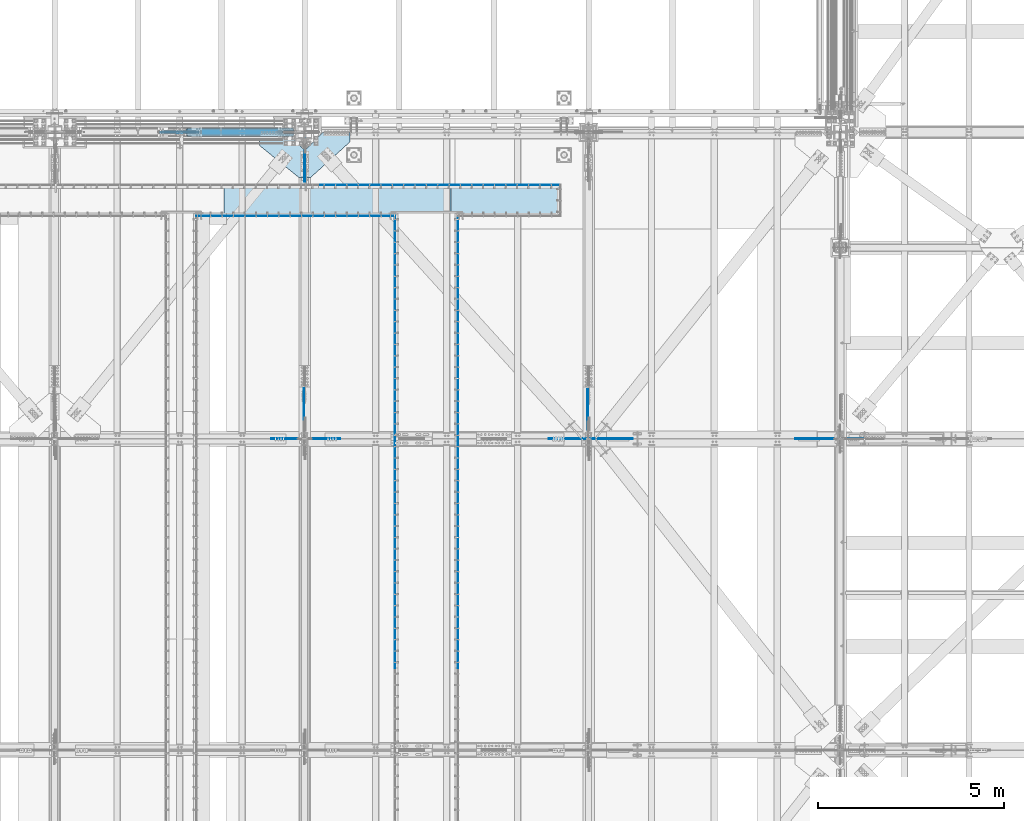
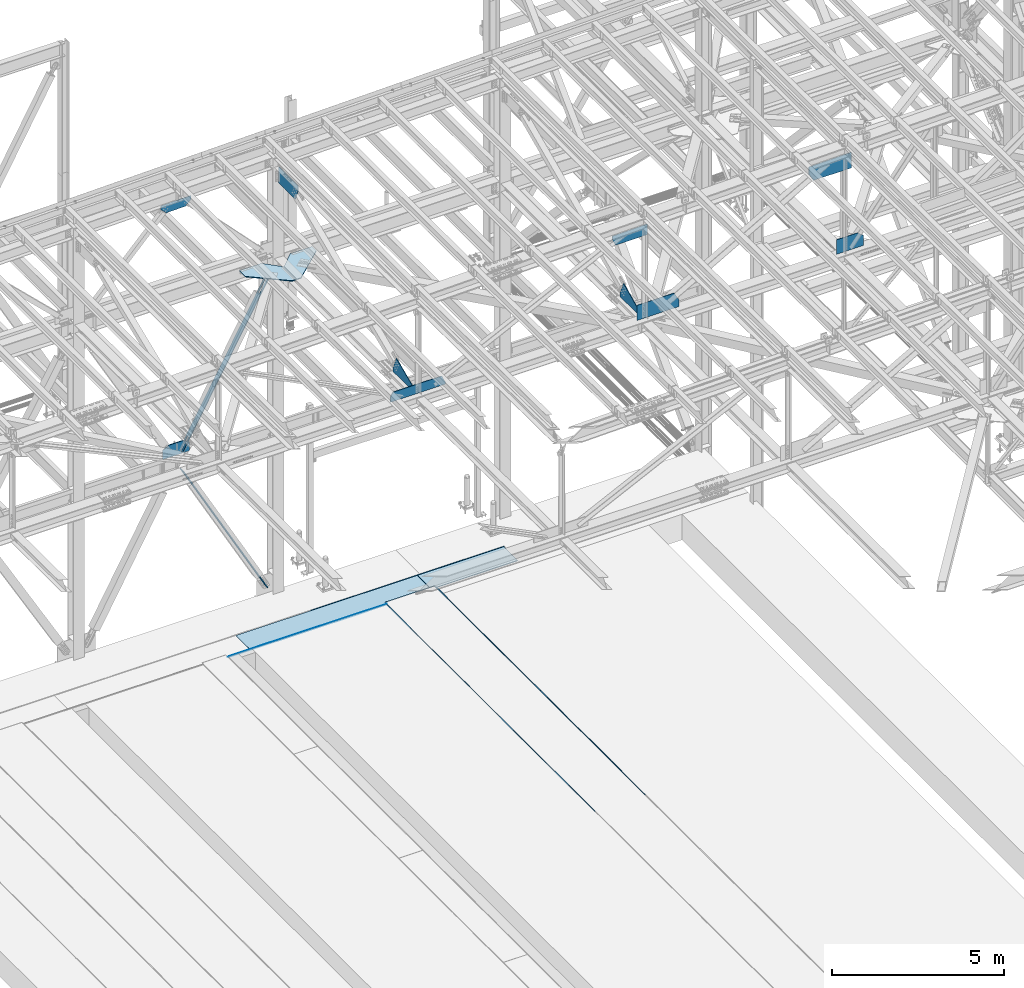
# One storey, part 2993 of 3843: 22 plates, 18 elements without a shape of their own.
"""IFC2X3 building model written with IfcOpenShell, lengths in millimetres."""

import ifcopenshell
import ifcopenshell.guid

model = None  # the IFC model being written
_history = None  # IfcOwnerHistory: only IFC2X3 demands one
_inside = {}  # id of a spatial element -> (the spatial element, [elements in it])
_under = {}  # id of a project, library or spatial element -> (it, [spatial elements below it])
_declared = {}  # id of a project -> (the project, [libraries it declares])
_typed = {}  # id of a type object -> (the type object, [elements of that type])
_made_of = {}  # id of a material, layer set ... -> (it, [elements and type objects made of it])


def new_model(schema):
    """Start an empty IFC model of exactly this schema.

    Asked for "IFC4X3", IfcOpenShell would pick the latest addendum, in which some entities
    have other attributes; the version numbers below select the first issue.
    IFC2X3 requires an IfcOwnerHistory on every rooted entity: one is made here for all.
    """
    global model, _history
    if schema == "IFC4X3":
        model = ifcopenshell.file(schema_version=(4, 3, 0, 0))
    else:
        model = ifcopenshell.file(schema=schema)
    _inside.clear()
    _under.clear()
    _declared.clear()
    _typed.clear()
    _made_of.clear()
    _history = None
    if model.schema == "IFC2X3":
        org = make("IfcOrganization", Name="unknown")
        user = make(
            "IfcPersonAndOrganization",
            ThePerson=make("IfcPerson", FamilyName="unknown"),
            TheOrganization=org,
        )
        app = make(
            "IfcApplication",
            ApplicationDeveloper=org,
            Version="unknown",
            ApplicationFullName="unknown",
            ApplicationIdentifier="unknown",
        )
        _history = make(
            "IfcOwnerHistory",
            OwningUser=user,
            OwningApplication=app,
            ChangeAction="ADDED",
            CreationDate=0,
        )
    return model


def make(cls, **values):
    """One entity of the class cls with the attributes given. An attribute that is None is left unset."""
    return model.create_entity(
        cls, **{name: value for name, value in values.items() if value is not None}
    )


def rooted(cls, **values):
    """An entity with a GlobalId (a new one), such as an element, a storey or a relation."""
    return make(cls, GlobalId=ifcopenshell.guid.new(), OwnerHistory=_history, **values)


def si_unit(unit_type, name, prefix=None):
    """IfcSIUnit, for example si_unit("LENGTHUNIT", "METRE", prefix="MILLI")."""
    return make("IfcSIUnit", UnitType=unit_type, Prefix=prefix, Name=name)


def assignment(units):
    """IfcUnitAssignment: the units of a project."""
    return None if units is None else make("IfcUnitAssignment", Units=units)


def point(xyz):
    """IfcCartesianPoint."""
    return None if xyz is None else make("IfcCartesianPoint", Coordinates=xyz)


def direction(xyz):
    """IfcDirection."""
    return None if xyz is None else make("IfcDirection", DirectionRatios=xyz)


def frame(location, z_axis=None, x_axis=None):
    """IfcAxis2Placement3D, a coordinate frame: its origin and axes. An axis left out is left unset."""
    return make(
        "IfcAxis2Placement3D",
        Location=point(location),
        Axis=direction(z_axis),
        RefDirection=direction(x_axis),
    )


def origin_with_axes():
    """The frame at (0, 0, 0) with the z axis (0, 0, 1) and the x axis (1, 0, 0) written out."""
    return frame((0.0, 0.0, 0.0), z_axis=(0.0, 0.0, 1.0), x_axis=(1.0, 0.0, 0.0))


def place(relative_to, where):
    """IfcLocalPlacement: puts the frame where relative to a parent placement (None: the world)."""
    return make(
        "IfcLocalPlacement", PlacementRelTo=relative_to, RelativePlacement=where
    )


def context(
    kind, dimensions, precision=None, world=None, true_north=None, identifier=None
):
    """IfcGeometricRepresentationContext, for example the 3D "Model" context."""
    return make(
        "IfcGeometricRepresentationContext",
        ContextIdentifier=identifier,
        ContextType=kind,
        CoordinateSpaceDimension=dimensions,
        Precision=precision,
        WorldCoordinateSystem=world,
        TrueNorth=true_north,
    )


def subcontext(parent, identifier, kind, view, scale=None):
    """IfcGeometricRepresentationSubContext, for example "Body" below "Model"."""
    return make(
        "IfcGeometricRepresentationSubContext",
        ContextIdentifier=identifier,
        ContextType=kind,
        ParentContext=parent,
        TargetScale=scale,
        TargetView=view,
    )


def project(units=None, contexts=None):
    """IfcProject with its units and contexts."""
    return rooted(
        "IfcProject",
        Name="project",
        RepresentationContexts=contexts,
        UnitsInContext=assignment(units),
    )


def spatial(cls, under=None, at=None, **own):
    """A site, building, storey or space (cls), placed at a placement, below another one or the project."""
    s = rooted(cls, ObjectPlacement=at, **own)
    if under is not None:
        _under.setdefault(under.id(), (under, []))[1].append(s)
    return s


def faces_of(points, faces, orient=None, outer=None):
    """IfcFace entities. A face is a list of loops; a loop is a list of indices into points, from 0.

    orient and outer hold one flag for each loop. By default every Orientation is true, the
    first loop of a face is its IfcFaceOuterBound and the others are IfcFaceBound.
    """
    made = []
    for i, loops in enumerate(faces):
        bounds = []
        for j, loop in enumerate(loops):
            is_outer = j == 0 if outer is None else outer[i][j]
            bounds.append(
                make(
                    "IfcFaceOuterBound" if is_outer else "IfcFaceBound",
                    Bound=make("IfcPolyLoop", Polygon=[points[k] for k in loop]),
                    Orientation=True if orient is None else orient[i][j],
                )
            )
        made.append(make("IfcFace", Bounds=bounds))
    return made


def faceted_brep(points, faces, orient=None, outer=None, voids=None):
    """IfcFacetedBrep: a solid bounded by flat faces; with voids (closed shells), ...WithVoids."""
    shared = [point(p) for p in points]
    hull = make("IfcClosedShell", CfsFaces=faces_of(shared, faces, orient, outer))
    if voids is None:
        return make("IfcFacetedBrep", Outer=hull)
    return make(
        "IfcFacetedBrepWithVoids",
        Outer=hull,
        Voids=[
            make(cls, CfsFaces=faces_of(shared, fs, o, b)) for cls, fs, o, b in voids
        ],
    )


def shape(context_of_items, identifier, shape_type, items):
    """IfcShapeRepresentation: the items that make up one representation, for example the "Body"."""
    return make(
        "IfcShapeRepresentation",
        ContextOfItems=context_of_items,
        RepresentationIdentifier=identifier,
        RepresentationType=shape_type,
        Items=items,
    )


def material(Name=None, Category=None):
    """IfcMaterial."""
    return make("IfcMaterial", Name=Name, Category=Category)


def made_of(thing, what):
    """Note that an element or type object is made of a material, layer set ...; save() writes the relation."""
    if what is not None:
        _made_of.setdefault(what.id(), (what, []))[1].append(thing)
    return thing


def type_object(cls, material=None, **own):
    """A type object (cls), such as IfcWallType, which elements share."""
    return made_of(rooted(cls, **own), material)


def element(
    cls,
    number,
    at=None,
    inside=None,
    cuts=None,
    type_object=None,
    material=None,
    context=None,
    identifier="Body",
    shape_type=None,
    held_by="IfcProductDefinitionShape",
    body=None,
    shapes=None,
    **own,
):
    """One element of the class cls, such as IfcWall. Its Tag is "e" and its number.

    at: its placement. inside: the storey or other place that contains it. cuts: it is an
    opening in that element (IfcRelVoidsElement). A single representation is given by context,
    identifier, shape_type and body (its items); several are given by shapes. held_by: the class
    of the entity that holds the representations. save() writes the other relations.
    """
    e = rooted(cls, Tag="e%d" % number, ObjectPlacement=at, **own)
    if body is not None:
        shapes = [shape(context, identifier, shape_type, body)]
    if shapes is not None:
        e.Representation = make(held_by, Representations=shapes)
    if inside is not None:
        _inside.setdefault(inside.id(), (inside, []))[1].append(e)
    if cuts is not None:
        rooted(
            "IfcRelVoidsElement", RelatingBuildingElement=cuts, RelatedOpeningElement=e
        )
    if type_object is not None:
        _typed.setdefault(type_object.id(), (type_object, []))[1].append(e)
    return made_of(e, material)


def aggregate(whole, parts):
    """IfcRelAggregates: a whole, such as a stair, and the parts it consists of."""
    return rooted("IfcRelAggregates", RelatingObject=whole, RelatedObjects=parts)


def save(model, path):
    """Write the relations noted so far, then the file.

    IfcRelAggregates (storeys below a building ...), IfcRelContainedInSpatialStructure (elements
    in a storey), IfcRelDefinesByType, IfcRelAssociatesMaterial and IfcRelDeclares: one each for
    every whole, place, type object, material and project.
    """
    for whole, parts in _under.values():
        aggregate(whole, parts)
    for where, things in _inside.values():
        rooted(
            "IfcRelContainedInSpatialStructure",
            RelatedElements=things,
            RelatingStructure=where,
        )
    for kind, things in _typed.values():
        rooted("IfcRelDefinesByType", RelatedObjects=things, RelatingType=kind)
    for what, things in _made_of.values():
        rooted("IfcRelAssociatesMaterial", RelatedObjects=things, RelatingMaterial=what)
    for by, libraries in _declared.values():
        rooted("IfcRelDeclares", RelatingContext=by, RelatedDefinitions=libraries)
    model.write(path)


model = new_model("IFC2X3")

# Units and contexts
model_context = context("Model", 3, precision=1e-05, world=origin_with_axes())
body_context = subcontext(model_context, "Body", "Model", "MODEL_VIEW")
ifc_project = project(units=[si_unit("LENGTHUNIT", "METRE", prefix="MILLI"), si_unit("AREAUNIT", "SQUARE_METRE"), si_unit("VOLUMEUNIT", "CUBIC_METRE"), si_unit("MASSUNIT", "GRAM", prefix="KILO"), si_unit("TIMEUNIT", "SECOND"), si_unit("PLANEANGLEUNIT", "RADIAN"), si_unit("SOLIDANGLEUNIT", "STERADIAN"), si_unit("THERMODYNAMICTEMPERATUREUNIT", "DEGREE_CELSIUS"), si_unit("LUMINOUSINTENSITYUNIT", "LUMEN")], contexts=[model_context])

# Site, building, storey
site_placement = place(None, origin_with_axes())
site = spatial("IfcSite", under=ifc_project, at=site_placement, CompositionType="ELEMENT")
building_placement = place(site_placement, origin_with_axes())
building = spatial("IfcBuilding", under=site, at=building_placement, Name="Undefined", CompositionType="ELEMENT")
storey_placement = place(building_placement, origin_with_axes())
storey = spatial("IfcBuildingStorey", under=building, at=storey_placement, Name="Undefined", CompositionType="ELEMENT", Elevation=0.0)

# Assembly, plate
assembly_1_placement = place(storey_placement, origin_with_axes())
assembly_1 = element("IfcElementAssembly", 1, at=assembly_1_placement, inside=storey, Name="EMBED_ANGLE", AssemblyPlace="NOTDEFINED", PredefinedType="RIGID_FRAME")
ifc_material_1 = material(Name="STEEL/A36")
plate_type_1 = type_object("IfcPlateType", PredefinedType="NOTDEFINED")
plate_1_placement = place(assembly_1_placement, frame((59728.8922303365, 89966.672572964, 30480.0000003815), z_axis=(0.99999999999915, 1.30400000489317e-06, 0.0), x_axis=(0.0, 0.0, -1.0)))
plate_1 = element("IfcPlate", 2, at=plate_1_placement, type_object=plate_type_1, material=ifc_material_1, Name="PLATE", context=body_context, shape_type="Brep", body=[
    faceted_brep([(9.05856722965837e-10, -6.35000000003492, 12.6694927635544), (7.27595761418343e-12, 6.3499999046162, 0.0), (25.3999999999942, 6.34999999994034, 2.91038304567337e-11), (25.3999996185303, -1.58775845066702, 7.90726318286033), (20.6374996185186, -6.35000000003492, 12.6694927635544), (25.3999996185303, 6.34999998462445, 5340.37764092155), (25.3999996185194, -1.59503698302433, 5332.38252787699), (20.6374996185186, -6.35000001534354, 5327.62760207739), (3.8056168705225e-07, -6.35000001534354, 5327.62760207738), (3.81471181754023e-07, 6.34999998462445, 5340.37764091983)], [[[0, 1, 2, 3, 4]], [[3, 2, 5, 6]], [[4, 3, 6, 7]], [[0, 4, 7, 8]], [[1, 0, 8, 9]], [[2, 1, 9, 5]], [[8, 7, 6, 5, 9]]]),
])
aggregate(assembly_1, [plate_1])

assembly_2_placement = place(storey_placement, origin_with_axes())
assembly_2 = element("IfcElementAssembly", 3, at=assembly_2_placement, inside=storey, Name="EMBED_ANGLE", AssemblyPlace="NOTDEFINED", PredefinedType="RIGID_FRAME")
plate_2_placement = place(assembly_2_placement, frame((62999.1113387973, 90792.1730712506, 30480.0000003815), z_axis=(1.0, 0.0, 0.0), x_axis=(0.0, 0.0, -1.0)))
plate_2 = element("IfcPlate", 4, at=plate_2_placement, type_object=plate_type_1, material=ifc_material_1, Name="PLATE", context=body_context, shape_type="Brep", body=[
    faceted_brep([(25.3999998098334, 1.58752319247287, 6497.63818407567), (20.6374996185259, 6.34999999188585, 6502.40066136965), (3.81471181754023e-07, 6.34999999188585, 6502.40066136825), (3.80725396098569e-07, -6.35000000809669, 6489.70066138042), (25.3999996185303, -6.35000000809669, 6489.70066138042), (25.3999996185303, -6.34999999999491, 2.91038304567337e-11), (0.0, -6.3499999046162, 0.0), (7.27595761418343e-12, 6.3499999046162, 0.0), (20.6374996185295, 6.35000000000218, -7.27595761418343e-12), (25.3999996185921, 1.58750000000146, 7.27595761418343e-11)], [[[0, 1, 2, 3, 4]], [[5, 6, 7, 8, 9]], [[5, 9, 0, 4]], [[6, 5, 4, 3]], [[7, 6, 3, 2]], [[8, 7, 2, 1]], [[9, 8, 1, 0]]]),
])
aggregate(assembly_2, [plate_2])

assembly_3_placement = place(storey_placement, origin_with_axes())
assembly_3 = element("IfcElementAssembly", 5, at=assembly_3_placement, inside=storey, Name="EMBED_ANGLE", AssemblyPlace="NOTDEFINED", PredefinedType="RIGID_FRAME")
plate_3_placement = place(assembly_3_placement, frame((66751.962, 83927.8228007812, 30480.0), z_axis=(0.0, -1.0, 0.0), x_axis=(0.0, 0.0, -1.0)))
plate_3 = element("IfcPlate", 6, at=plate_3_placement, type_object=plate_type_1, material=ifc_material_1, Name="PLATE", context=body_context, shape_type="Brep", body=[
    faceted_brep([(25.399999579975, 1.58750000000873, 6096.0000061035), (25.3999996185921, 1.58750000000146, 7.27595761418343e-11), (20.6374996185295, 6.35000000000218, -7.27595761418343e-12), (20.6374984696922, 6.35000000000582, 6096.0), (0.0, -6.3499999046162, 0.0), (3.81471181754023e-07, -6.34999999999854, 6096.0), (3.81471181754023e-07, 6.34999999999854, 6096.0), (7.27595761418343e-12, 6.3499999046162, 0.0), (25.3999996185303, -6.34999999999491, 2.91038304567337e-11), (25.3999996185303, -6.35000000000582, 6096.0)], [[[0, 1, 2, 3]], [[4, 5, 6, 7]], [[8, 9, 5, 4]], [[6, 5, 9, 0, 3]], [[7, 6, 3, 2]], [[8, 4, 7, 2, 1]], [[9, 8, 1, 0]]]),
])
aggregate(assembly_3, [plate_3])

assembly_4_placement = place(storey_placement, origin_with_axes())
assembly_4 = element("IfcElementAssembly", 7, at=assembly_4_placement, inside=storey, Name="EMBED_ANGLE", AssemblyPlace="NOTDEFINED", PredefinedType="RIGID_FRAME")
plate_4_placement = place(assembly_4_placement, frame((66751.962, 89973.0228007813, 30480.0000003815), z_axis=(0.0, -1.0, 0.0), x_axis=(0.0, 0.0, -1.0)))
plate_4 = element("IfcPlate", 8, at=plate_4_placement, type_object=plate_type_1, material=ifc_material_1, Name="PLATE", context=body_context, shape_type="Brep", body=[
    faceted_brep([(3.81471181754023e-07, 6.35000000000582, 6045.20000000001), (3.81471181754023e-07, -6.35000000000582, 6045.20000000001), (25.3999996185303, -6.35000000000582, 6045.20000000001), (25.399999579975, 1.58750000000873, 6045.20000000001), (20.6374984696922, 6.35000000000582, 6045.20000000001), (25.3999996184793, 1.58750000000873, 7.93788274674444), (20.6374984696922, 6.35000000000582, 12.7003817431978), (8.00355337560177e-10, 6.35000000000582, 12.7003817431978), (0.0, -6.3499999046162, 0.0), (25.3999996185303, -6.34999999999491, 2.91038304567337e-11)], [[[0, 1, 2, 3, 4]], [[4, 3, 5, 6]], [[0, 4, 6, 7]], [[1, 0, 7, 8]], [[2, 1, 8, 9]], [[3, 2, 9, 5]], [[8, 7, 6, 5, 9]]]),
])
aggregate(assembly_4, [plate_4])

assembly_5_placement = place(storey_placement, origin_with_axes())
assembly_5 = element("IfcElementAssembly", 9, at=assembly_5_placement, inside=storey, Name="EMBED_ANGLE", AssemblyPlace="NOTDEFINED", PredefinedType="RIGID_FRAME")
plate_5_placement = place(assembly_5_placement, frame((65062.9255556641, 83927.822703125, 30480.0), z_axis=(0.0, -1.0, 0.0), x_axis=(0.0, 0.0, -1.0)))
plate_5 = element("IfcPlate", 10, at=plate_5_placement, type_object=plate_type_1, material=ifc_material_1, Name="PLATE", context=body_context, shape_type="Brep", body=[
    faceted_brep([(25.3999996185521, -1.58750000003783, 6096.0), (20.6375003814719, -6.34999999999854, 6096.00000000139), (20.6375000381231, -6.35000000004948, 2.5465851649642e-11), (25.3999996185921, -1.5874999999869, 7.27595761418343e-11), (0.0, -6.3499999046162, 0.0), (3.81471181754023e-07, -6.34999999999854, 6096.0), (3.81471181754023e-07, 6.34999999999854, 6096.0), (7.27595761418343e-12, 6.3499999046162, 0.0), (25.3999996185303, 6.34999999999854, 6096.00000000171), (25.3999999999942, 6.34999999994034, 2.91038304567337e-11)], [[[0, 1, 2, 3]], [[4, 5, 6, 7]], [[8, 9, 7, 6]], [[9, 8, 0, 3]], [[4, 7, 9, 3, 2]], [[5, 4, 2, 1]], [[8, 6, 5, 1, 0]]]),
])
aggregate(assembly_5, [plate_5])

assembly_6_placement = place(storey_placement, origin_with_axes())
assembly_6 = element("IfcElementAssembly", 11, at=assembly_6_placement, inside=storey, Name="EMBED_ANGLE", AssemblyPlace="NOTDEFINED", PredefinedType="RIGID_FRAME")
plate_6_placement = place(assembly_6_placement, frame((65062.9255556641, 89973.022703125, 30480.0000003815), z_axis=(0.0, -1.0, 0.0), x_axis=(0.0, 0.0, -1.0)))
plate_6 = element("IfcPlate", 12, at=plate_6_placement, type_object=plate_type_1, material=ifc_material_1, Name="PLATE", context=body_context, shape_type="Brep", body=[
    faceted_brep([(25.3999996185303, 6.34999999999854, 6045.20000000001), (3.81471181754023e-07, 6.35000000000582, 6045.20000000001), (3.81471181754023e-07, -6.35000000000582, 6045.20000000001), (20.637498469714, -6.34999999999854, 6045.20000000001), (25.3999996185521, -1.58750000003783, 6045.20000000001), (25.3999996185303, -1.58750000003783, 7.87491767235042), (25.3999999999942, 6.34999999994034, 2.91038304567337e-11), (7.27595761418343e-12, 6.3499999046162, 0.0), (7.96717358753085e-10, -6.34999999999854, 12.6374673850223), (20.637498469714, -6.34999999999854, 12.6374673850223)], [[[0, 1, 2, 3, 4]], [[0, 4, 5, 6]], [[1, 0, 6, 7]], [[2, 1, 7, 8]], [[3, 2, 8, 9]], [[4, 3, 9, 5]], [[8, 7, 6, 5, 9]]]),
])
aggregate(assembly_6, [plate_6])

assembly_7_placement = place(storey_placement, origin_with_axes())
assembly_7 = element("IfcElementAssembly", 13, at=assembly_7_placement, inside=storey, Name="PLATE", AssemblyPlace="NOTDEFINED", PredefinedType="RIGID_FRAME")
ifc_material_2 = material(Name="STEEL/A572-50")
plate_type_2 = type_object("IfcPlateType", PredefinedType="NOTDEFINED")
plate_7_placement = place(assembly_7_placement, frame((66570.9866227941, 90779.4725590849, 30467.3), z_axis=(1.0, 0.0, 0.0), x_axis=(0.0, -1.0, 0.0)))
plate_7 = element("IfcPlate", 14, at=plate_7_placement, type_object=plate_type_2, material=ifc_material_2, Name="PLATE", context=body_context, shape_type="Brep", body=[
    faceted_brep([(708.024572977112, -12.7000000000007, 9.74978320300579e-10), (708.024572977112, 12.7000000000007, 9.74978320300579e-10), (708.024574108116, 12.7000000000007, 165.086527491294), (708.024574108116, -12.7000000000007, 165.086527491294), (800.100292422983, -12.7000000000007, 165.086527491294), (800.100292422983, 12.7000000000007, 165.086527491294), (0.0, -12.6999999999971, 0.0), (0.000218359578866512, -12.7000000000007, 2911.46147315594), (0.000218359578866512, 12.7000000000007, 2911.46147315594), (0.0, 12.6999999999971, 0.0), (800.10021835957, -12.7000000000007, 2911.46147315705), (800.10021835957, 12.7000000000007, 2911.46147315705)], [[[0, 1, 2, 3]], [[4, 3, 2, 5]], [[6, 7, 8, 9]], [[7, 10, 11, 8]], [[11, 10, 4, 5]], [[1, 9, 8, 11, 5, 2]], [[6, 9, 1, 0]], [[10, 7, 6, 0, 3, 4]]]),
])
aggregate(assembly_7, [plate_7])

assembly_8_placement = place(storey_placement, origin_with_axes())
assembly_8 = element("IfcElementAssembly", 15, at=assembly_8_placement, inside=storey, Name="PLATE", AssemblyPlace="NOTDEFINED", PredefinedType="RIGID_FRAME")
plate_8_placement = place(assembly_8_placement, frame((60471.8116227941, 90779.4730023771, 30467.3), z_axis=(1.0, 0.0, 0.0), x_axis=(0.0, -1.0, 0.0)))
plate_8 = element("IfcPlate", 16, at=plate_8_placement, type_object=plate_type_2, material=ifc_material_2, Name="PLATE", context=body_context, shape_type="Brep", body=[
    faceted_brep([(708.025016285523, -12.7000000000007, 6096.00000000254), (708.025005959891, -12.7000000000007, 4594.27507765742), (708.025005959891, 12.7000000000007, 4594.27507765742), (708.025016285523, 12.7000000000007, 6096.00000000254), (800.099813318637, -12.7000000000007, 4594.27507765755), (800.099813318637, 12.7000000000007, 4594.27507765755), (0.0, -12.6999999999971, 0.0), (0.000443292199634016, -12.7000000000007, 6096.00000000001), (0.000443292199634016, 12.7000000000007, 6096.00000000001), (0.0, 12.6999999999971, 0.0), (800.099702970721, -12.7000000000007, 2.86672729998827e-09), (800.099702970721, 12.7000000000007, 2.86672729998827e-09)], [[[0, 1, 2, 3]], [[4, 5, 2, 1]], [[6, 7, 8, 9]], [[10, 6, 9, 11]], [[0, 7, 6, 10, 4, 1]], [[8, 7, 0, 3]], [[11, 9, 8, 3, 2, 5]], [[10, 11, 5, 4]]]),
])
aggregate(assembly_8, [plate_8])

assembly_9_placement = place(storey_placement, origin_with_axes())
assembly_9 = element("IfcElementAssembly", 17, at=assembly_9_placement, inside=storey, Name="CB", AssemblyPlace="NOTDEFINED", PredefinedType="RIGID_FRAME")
plate_type_3 = type_object("IfcPlateType", PredefinedType="NOTDEFINED")
plate_9_placement = place(assembly_9_placement, frame((59450.4464539676, 92117.8625, 36501.1433930023), z_axis=(0.48827172176639, 0.0, 0.872691655582477), x_axis=(0.0, 1.0, 0.0)))
plate_9 = element("IfcPlate", 18, at=plate_9_placement, type_object=plate_type_3, material=ifc_material_1, Name="CB", context=body_context, shape_type="Brep", body=[
    faceted_brep([(0.0, -12.7000000001135, 65.0875015259007), (0.0, -12.699999985547, 5868.19609691995), (0.0, 12.7000000144762, 5868.19609691988), (0.0, 12.6999999999025, 65.0875015259462), (4.95449104382715, -12.6999999854888, 5893.10400540797), (4.95449104382715, 12.7000000145345, 5893.10400540791), (19.063687826434, -12.6999999854306, 5914.21991061944), (19.063687826434, 12.7000000145927, 5914.21991061938), (40.1795930378867, -12.6999999854015, 5928.32910740207), (40.1795930378867, 12.7000000146218, 5928.32910740201), (65.0874999999942, -12.699999985387, 5933.28359844591), (65.0874999999942, 12.7000000146363, 5933.28359844584), (65.0874999999942, -12.6999999866966, 5401.86679924902), (65.0874999999942, 12.7000000133266, 5401.86679924896), (128.587499999994, -12.6999999866966, 5401.86679924902), (128.587499999994, 12.7000000133266, 5401.86679924896), (128.587498474109, -12.699999985387, 5933.28359844591), (128.587498474109, 12.7000000146363, 5933.28359844584), (153.495406962102, -12.6999999854015, 5928.32910740207), (153.495406962102, 12.7000000146218, 5928.32910740201), (174.611312173554, -12.6999999854306, 5914.21991061944), (174.611312173554, 12.7000000145927, 5914.21991061938), (188.720508956161, -12.6999999854888, 5893.10400540797), (188.720508956161, 12.7000000145345, 5893.10400540791), (193.674999999988, -12.699999985547, 5868.19609691995), (193.674999999988, 12.7000000144762, 5868.19609691988), (193.674999999988, -12.7000000001135, 65.0875015259007), (193.674999999988, 12.6999999999025, 65.0875015259462), (188.720508956161, -12.7000000000698, 40.1795930378939), (188.720508956161, 12.6999999999389, 40.1795930379376), (174.611312173554, -12.7000000000407, 19.0636878264304), (174.611312173554, 12.6999999999753, 19.0636878264741), (153.495406962102, -12.7000000000189, 4.9544910438035), (153.495406962102, 12.7000000000044, 4.95449104384716), (128.587499999994, -12.7000000000044, -2.00088834390044e-11), (128.587499999994, 12.7000000000116, 1.81898940354586e-11), (128.587499999994, -12.6999999980762, 531.416799185412), (128.587499999994, 12.7000000018015, 531.416799185514), (65.0874999999942, -12.6999999980762, 531.416799185412), (65.0874999999942, 12.7000000018015, 531.416799185514), (65.0875015258789, -12.7000000000044, -2.00088834390044e-11), (65.0875015258789, 12.7000000000116, 1.81898940354586e-11), (40.1795930378867, -12.7000000000189, 4.9544910438035), (40.1795930378867, 12.7000000000044, 4.95449104384716), (19.063687826434, -12.7000000000407, 19.0636878264304), (19.063687826434, 12.6999999999753, 19.0636878264741), (4.95449104382715, -12.7000000000698, 40.1795930378939), (4.95449104382715, 12.6999999999389, 40.1795930379376)], [[[0, 1, 2, 3]], [[1, 4, 5, 2]], [[4, 6, 7, 5]], [[6, 8, 9, 7]], [[8, 10, 11, 9]], [[10, 12, 13, 11]], [[12, 14, 15, 13]], [[14, 16, 17, 15]], [[16, 18, 19, 17]], [[18, 20, 21, 19]], [[20, 22, 23, 21]], [[22, 24, 25, 23]], [[24, 26, 27, 25]], [[26, 28, 29, 27]], [[28, 30, 31, 29]], [[30, 32, 33, 31]], [[32, 34, 35, 33]], [[34, 36, 37, 35]], [[36, 38, 39, 37]], [[38, 40, 41, 39]], [[40, 42, 43, 41]], [[42, 44, 45, 43]], [[44, 46, 47, 45]], [[46, 0, 3, 47]], [[5, 7, 9, 11, 13, 15, 17, 19, 21, 23, 25, 27, 29, 31, 33, 35, 37, 39, 41, 43, 45, 47, 3, 2]], [[46, 44, 42, 40, 38, 36, 34, 32, 30, 28, 26, 24, 22, 20, 18, 16, 14, 12, 10, 8, 6, 4, 1, 0]]]),
])
aggregate(assembly_9, [plate_9])

assembly_10_placement = place(storey_placement, origin_with_axes())
assembly_10 = element("IfcElementAssembly", 19, at=assembly_10_placement, inside=storey, Name="CB", AssemblyPlace="NOTDEFINED", PredefinedType="RIGID_FRAME")
plate_type_4 = type_object("IfcPlateType", PredefinedType="NOTDEFINED")
plate_10_placement = place(assembly_10_placement, frame((62334.5160236875, 92327.4125, 30683.2641457135), z_axis=(-0.483755372180955, 0.0, 0.875203256327389), x_axis=(0.0, -1.0, 0.0)))
plate_10 = element("IfcPlate", 20, at=plate_10_placement, type_object=plate_type_4, material=ifc_material_1, Name="CB", context=body_context, shape_type="Brep", body=[
    faceted_brep([(0.0, -15.8749999998581, 77.7874984741429), (0.0, -15.8750000088621, 5849.62723327328), (0.0, 15.8749999911088, 5849.62723327333), (0.0, 15.8750000001437, 77.7874984740847), (5.92122074862709, -15.8750000089058, 5879.39522018442), (5.92122074862709, 15.8749999910651, 5879.39522018447), (22.7834308115271, -15.8750000089422, 5904.63130093583), (22.7834308115271, 15.874999991036, 5904.63130093587), (48.0195115629467, -15.875000008964, 5921.49351099871), (48.0195115629467, 15.8749999910069, 5921.49351099876), (77.7874999999913, -15.8750000089785, 5927.41473174734), (77.7874999999913, 15.8749999909924, 5927.41473174738), (77.7874999999913, -15.8750000080327, 5303.6823658783), (77.7874999999913, 15.8749999919382, 5303.68236587834), (147.637499999997, -15.8750000080327, 5303.6823658783), (147.637499999997, 15.8749999919382, 5303.68236587834), (147.637501525867, -15.8750000089785, 5927.41473174734), (147.637501525867, 15.8749999909924, 5927.41473174738), (177.405488437042, -15.875000008964, 5921.49351099871), (177.405488437042, 15.8749999910069, 5921.49351099876), (202.641569188461, -15.8750000089422, 5904.63130093583), (202.641569188461, 15.874999991036, 5904.63130093587), (219.503779251361, -15.8750000089058, 5879.39522018442), (219.503779251361, 15.8749999910651, 5879.39522018447), (225.424999999988, -15.8750000088621, 5849.62723327328), (225.424999999988, 15.8749999911088, 5849.62723327333), (225.425000000003, -15.8749999998581, 77.7874984741429), (225.425000000003, 15.8750000001437, 77.7874984740847), (219.503779251376, -15.8749999999109, 48.0195115629685), (219.503779251376, 15.8750000000891, 48.0195115629249), (202.641569188469, -15.8749999999582, 22.7834308115562), (202.641569188469, 15.87500000004, 22.7834308115052), (177.405488437056, -15.8749999999891, 5.92122074864892), (177.405488437056, 15.8750000000109, 5.92122074859071), (147.637500000004, -15.8749999999982, 2.18278728425503e-11), (147.637500000004, 15.8750000000018, -2.91038304567337e-11), (147.637500000004, -15.8749999988613, 623.732365867771), (147.637500000004, 15.8750000011369, 623.732365867712), (77.7874999999985, -15.8749999988613, 623.732365867771), (77.7874999999985, 15.8750000011369, 623.732365867712), (77.7874984741211, -15.8749999999982, 2.18278728425503e-11), (77.7874984741211, 15.8750000000018, -2.91038304567337e-11), (48.0195115629467, -15.8749999999891, 5.92122074864892), (48.0195115629467, 15.8750000000109, 5.92122074859071), (22.7834308115343, -15.8749999999582, 22.7834308115562), (22.7834308115343, 15.87500000004, 22.7834308115052), (5.92122074862709, -15.8749999999109, 48.0195115629685), (5.92122074862709, 15.8750000000891, 48.0195115629249)], [[[0, 1, 2, 3]], [[1, 4, 5, 2]], [[4, 6, 7, 5]], [[6, 8, 9, 7]], [[8, 10, 11, 9]], [[10, 12, 13, 11]], [[12, 14, 15, 13]], [[14, 16, 17, 15]], [[16, 18, 19, 17]], [[18, 20, 21, 19]], [[20, 22, 23, 21]], [[22, 24, 25, 23]], [[24, 26, 27, 25]], [[26, 28, 29, 27]], [[28, 30, 31, 29]], [[30, 32, 33, 31]], [[32, 34, 35, 33]], [[34, 36, 37, 35]], [[36, 38, 39, 37]], [[38, 40, 41, 39]], [[40, 42, 43, 41]], [[42, 44, 45, 43]], [[44, 46, 47, 45]], [[46, 0, 3, 47]], [[5, 7, 9, 11, 13, 15, 17, 19, 21, 23, 25, 27, 29, 31, 33, 35, 37, 39, 41, 43, 45, 47, 3, 2]], [[46, 44, 42, 40, 38, 36, 34, 32, 30, 28, 26, 24, 22, 20, 18, 16, 14, 12, 10, 8, 6, 4, 1, 0]]]),
])
aggregate(assembly_10, [plate_10])

assembly_11_placement = place(storey_placement, origin_with_axes())
assembly_11 = element("IfcElementAssembly", 21, at=assembly_11_placement, inside=storey, Name="BEAM", AssemblyPlace="NOTDEFINED", PredefinedType="RIGID_FRAME")
plate_type_5 = type_object("IfcPlateType", PredefinedType="NOTDEFINED")
plate_11_placement = place(assembly_11_placement, frame((58834.4166674803, 92214.7, 36436.3), z_axis=(1.0, 0.0, 0.0), x_axis=(0.0, 0.0, 1.0)))
plate_11 = element("IfcPlate", 22, at=plate_11_placement, type_object=plate_type_5, material=ifc_material_2, Name="CB", context=body_context, shape_type="Brep", body=[
    faceted_brep([(0.0, -12.6999999999971, 0.0), (0.0, -12.6999999999971, 898.467041528711), (0.0, 12.6999999999971, 898.467041528711), (0.0, 12.6999999999971, 0.0), (319.298300364113, -12.6999999999971, 898.467041528711), (319.298300364113, 12.6999999999971, 898.467041528711), (438.71136425755, -12.6999999999971, 685.03919022833), (438.71136425755, 12.6999999999971, 685.03919022833), (438.71136425755, -12.6999999999971, 455.533334909014), (438.71136425755, 12.6999999999971, 455.533334909014), (438.71136425755, -12.6999999999971, 213.372966851726), (438.71136425755, 12.6999999999971, 213.372966851726), (319.379882066591, -12.6999999999971, 0.0), (319.379882066591, 12.6999999999971, 0.0)], [[[0, 1, 2, 3]], [[1, 4, 5, 2]], [[4, 6, 7, 5]], [[6, 8, 9, 7]], [[8, 10, 11, 9]], [[10, 12, 13, 11]], [[12, 0, 3, 13]], [[5, 7, 9, 11, 13, 3, 2]], [[12, 10, 8, 6, 4, 1, 0]]]),
])
aggregate(assembly_11, [plate_11])

assembly_12_placement = place(storey_placement, origin_with_axes())
assembly_12 = element("IfcElementAssembly", 23, at=assembly_12_placement, inside=storey, Name="PLATE", AssemblyPlace="NOTDEFINED", PredefinedType="RIGID_FRAME")
plate_type_6 = type_object("IfcPlateType", PredefinedType="NOTDEFINED")
plate_12_placement = place(assembly_12_placement, frame((62642.7499990228, 91732.1, 42232.2630004883), z_axis=(1.0, 0.0, 0.0), x_axis=(0.0, -1.0, 0.0)))
plate_12 = element("IfcPlate", 24, at=plate_12_placement, type_object=plate_type_6, material=ifc_material_2, Name="PLATE", context=body_context, shape_type="Brep", body=[
    faceted_brep([(0.0, -14.2874999999985, 0.0), (-476.24999999853, -14.2874999999985, 476.24999999311), (-476.24999999853, 14.2874999999985, 476.24999999311), (0.0, 14.2874999999985, 0.0), (-476.24999999853, -14.2874999999985, 1212.85000000025), (-476.24999999853, 14.2874999999985, 1212.85000000025), (-226.694020978277, -14.2874999999985, 1212.85000010189), (-226.694020978277, 14.2874999999985, 1212.85000010189), (736.600000090519, -14.2874999999985, 147.637499993114), (736.600000090519, 14.2874999999985, 147.637499993114), (736.599999940488, -14.2874999999985, 0.0), (736.599999940488, 14.2874999999985, 0.0)], [[[0, 1, 2, 3]], [[1, 4, 5, 2]], [[4, 6, 7, 5]], [[6, 8, 9, 7]], [[8, 10, 11, 9]], [[10, 0, 3, 11]], [[5, 7, 9, 11, 3, 2]], [[10, 8, 6, 4, 1, 0]]]),
])
aggregate(assembly_12, [plate_12])

assembly_13_placement = place(storey_placement, origin_with_axes())
assembly_13 = element("IfcElementAssembly", 25, at=assembly_13_placement, inside=storey, Name="PLATE", AssemblyPlace="NOTDEFINED", PredefinedType="RIGID_FRAME")
plate_13_placement = place(assembly_13_placement, frame((62153.799999016, 92208.3500000197, 42232.2630004883), z_axis=(0.0, -1.0, 0.0), x_axis=(-1.0, 0.0, 0.0)))
plate_13 = element("IfcPlate", 26, at=plate_13_placement, type_object=plate_type_6, material=ifc_material_2, Name="PLATE", context=body_context, shape_type="Brep", body=[
    faceted_brep([(0.0, -14.2874999999985, 0.0), (-476.24999999853, -14.2874999999985, 476.24999999311), (-476.24999999853, 14.2874999999985, 476.24999999311), (0.0, 14.2874999999985, 0.0), (-476.24999999853, -14.2874999999985, 1212.85000000025), (-476.24999999853, 14.2874999999985, 1212.85000000025), (-328.612499999996, -14.2874999999985, 1212.84999996016), (-328.612499999996, 14.2874999999985, 1212.84999996016), (736.600000000333, -14.2874999999985, 344.899074797329), (736.600000000333, 14.2874999999985, 344.899074797329), (736.599999940488, -14.2874999999985, 0.0), (736.599999940488, 14.2874999999985, 0.0)], [[[0, 1, 2, 3]], [[1, 4, 5, 2]], [[4, 6, 7, 5]], [[6, 8, 9, 7]], [[8, 10, 11, 9]], [[10, 0, 3, 11]], [[5, 7, 9, 11, 3, 2]], [[10, 8, 6, 4, 1, 0]]]),
])
aggregate(assembly_13, [plate_13])

assembly_14_placement = place(storey_placement, origin_with_axes())
assembly_14 = element("IfcElementAssembly", 27, at=assembly_14_placement, inside=storey, Name="BEAM", AssemblyPlace="NOTDEFINED", PredefinedType="RIGID_FRAME")
plate_type_7 = type_object("IfcPlateType", PredefinedType="NOTDEFINED")
plate_14_placement = place(assembly_14_placement, frame((62612.5875, 84198.6185006832, 42415.9685834627), z_axis=(0.0, 0.001528912000329, 0.999998831213365), x_axis=(0.0, 0.999998831213365, -0.00152891200032518)))
plate_14 = element("IfcPlate", 28, at=plate_14_placement, type_object=plate_type_7, material=ifc_material_2, context=body_context, shape_type="Brep", body=[
    faceted_brep([(0.0, -7.9375, 0.0), (9.45874489843845e-10, -7.9375, 177.799999999253), (9.45874489843845e-10, 7.9375, 177.799999999253), (0.0, 7.9375, 0.0), (937.98913140854, -7.9375, 586.816322255043), (937.98913140854, 7.9375, 586.816322255043), (1138.78046133036, -7.9375, 120.182802427655), (1138.78046133036, 7.9375, 120.182802427655), (1138.78045397729, -7.9375, 2.37923813983798e-09), (1138.78045397729, 7.9375, 2.37923813983798e-09)], [[[0, 1, 2, 3]], [[1, 4, 5, 2]], [[4, 6, 7, 5]], [[6, 8, 9, 7]], [[8, 0, 3, 9]], [[5, 7, 9, 3, 2]], [[8, 6, 4, 1, 0]]]),
])

# Assembly, plates
assembly_15_placement = place(storey_placement, origin_with_axes())
assembly_15 = element("IfcElementAssembly", 29, at=assembly_15_placement, inside=storey, Name="BEAM", AssemblyPlace="NOTDEFINED", PredefinedType="RIGID_FRAME")
plate_type_8 = type_object("IfcPlateType", PredefinedType="NOTDEFINED")
plate_15_placement = place(assembly_15_placement, frame((70232.5875, 84230.353184954, 42419.4896024763), z_axis=(0.0, 0.00197596199957479, 0.999998047785183), x_axis=(0.0, 0.999998047785183, -0.00197596199957261)))
plate_15 = element("IfcPlate", 30, at=plate_15_placement, type_object=plate_type_8, material=ifc_material_2, context=body_context, shape_type="Brep", body=[
    faceted_brep([(0.0, -7.9375, 0.0), (9.45874489843845e-10, -7.9375, 177.799999999253), (9.45874489843845e-10, 7.9375, 177.799999999253), (0.0, 7.9375, 0.0), (879.659493706262, -7.9375, 596.659929541034), (879.659493706262, 7.9375, 596.659929541034), (1088.29846107445, -7.9375, 133.482014158384), (1088.29846107445, 7.9375, 133.482014158384), (1088.29846107379, -7.9375, 2.55386112257838e-09), (1088.29846107379, 7.9375, 2.55386112257838e-09)], [[[0, 1, 2, 3]], [[1, 4, 5, 2]], [[4, 6, 7, 5]], [[6, 8, 9, 7]], [[8, 0, 3, 9]], [[5, 7, 9, 3, 2]], [[8, 6, 4, 1, 0]]]),
])
plate_type_9 = type_object("IfcPlateType", PredefinedType="NOTDEFINED")
plate_16_placement = place(assembly_15_placement, frame((77631.0779545186, 83985.1, 42450.5220261025), z_axis=(-0.00048281500021403, 0.0, 0.999999883444831), x_axis=(-0.999999883445314, 0.0, -0.000482814000210543)))
plate_16 = element("IfcPlate", 31, at=plate_16_placement, type_object=plate_type_9, material=ifc_material_2, Name="PLATE", context=body_context, shape_type="Brep", body=[
    faceted_brep([(0.0, -9.52500000000146, 0.0), (-2.40106601268053e-09, -9.52499999999418, 358.389367464872), (-2.40106601268053e-09, 9.52499999999418, 358.389367464872), (0.0, 9.52500000000146, 0.0), (200.41344519626, -9.52499999999418, 515.323152683522), (200.41344519626, 9.52499999999418, 515.323152683522), (897.429254753108, -9.52499999999418, 515.323152683071), (897.429254753108, 9.52499999999418, 515.323152683071), (897.429254756527, -9.52499999999418, -5.74800651520491e-10), (897.429254756527, 9.52499999999418, -5.74800651520491e-10)], [[[0, 1, 2, 3]], [[1, 4, 5, 2]], [[4, 6, 7, 5]], [[6, 8, 9, 7]], [[8, 0, 3, 9]], [[5, 7, 9, 3, 2]], [[8, 6, 4, 1, 0]]]),
])

# Assembly, plate
assembly_16_placement = place(storey_placement, origin_with_axes())
assembly_16 = element("IfcElementAssembly", 32, at=assembly_16_placement, inside=storey, Name="BEAM", AssemblyPlace="NOTDEFINED", PredefinedType="RIGID_FRAME")
plate_type_10 = type_object("IfcPlateType", PredefinedType="NOTDEFINED")
plate_17_placement = place(assembly_16_placement, frame((70370.700000017, 83985.1, 45755.8769105947), z_axis=(0.0216342480057937, 0.0, -0.999765952267441), x_axis=(-0.999765952267441, 0.0, -0.0216342480057875)))
plate_17 = element("IfcPlate", 33, at=plate_17_placement, type_object=plate_type_10, material=ifc_material_2, Name="PLATE", context=body_context, shape_type="Brep", body=[
    faceted_brep([(0.0, -9.52500000000146, 0.0), (8.20843651464384, -9.52500000000146, 379.329799747364), (8.20843651464384, 9.52500000000146, 379.329799747364), (0.0, 9.52500000000146, 0.0), (1073.83584040058, -9.52500000000146, 356.270354117114), (1073.83584040058, 9.52500000000146, 356.270354117114), (1179.5959061591, -9.52500000000146, 125.335712559034), (1179.5959061591, 9.52500000000146, 125.335712559034), (1179.59590615866, -9.52500000000146, -3.71073838323355e-09), (1179.59590615866, 9.52500000000146, -3.71073838323355e-09)], [[[0, 1, 2, 3]], [[1, 4, 5, 2]], [[4, 6, 7, 5]], [[6, 8, 9, 7]], [[8, 0, 3, 9]], [[5, 7, 9, 3, 2]], [[8, 6, 4, 1, 0]]]),
])

# Plate
plate_type_11 = type_object("IfcPlateType", PredefinedType="NOTDEFINED")
plate_18_placement = place(assembly_15_placement, frame((71434.6879554309, 83985.1, 42447.5303219094), z_axis=(-0.00048281500021403, 0.0, 0.999999883444831), x_axis=(-0.999999883445314, 0.0, -0.000482814000210543)))
plate_18 = element("IfcPlate", 34, at=plate_18_placement, type_object=plate_type_11, material=ifc_material_2, Name="PLATE", context=body_context, shape_type="Brep", body=[
    faceted_brep([(0.0, -9.52500000000146, 0.0), (-1.70257408171892e-09, -9.52499999999418, 250.12264494822), (-1.70257408171892e-09, 9.52499999999418, 250.12264494822), (0.0, 9.52500000000146, 0.0), (163.156416401165, -9.52499999999418, 537.985677975441), (163.156416401165, 9.52499999999418, 537.985677975441), (1406.63084540954, -9.52499999999418, 537.985677974626), (1406.63084540954, 9.52499999999418, 537.985677974626), (1406.63084541312, -9.52499999999418, -9.02218744158745e-10), (1406.63084541312, 9.52499999999418, -9.02218744158745e-10)], [[[0, 1, 2, 3]], [[1, 4, 5, 2]], [[4, 6, 7, 5]], [[6, 8, 9, 7]], [[8, 0, 3, 9]], [[5, 7, 9, 3, 2]], [[8, 6, 4, 1, 0]]]),
])

aggregate(assembly_15, [plate_15, plate_16, plate_18])

plate_type_12 = type_object("IfcPlateType", PredefinedType="NOTDEFINED")
plate_19_placement = place(assembly_14_placement, frame((63586.3682350942, 83985.1, 42443.7410339094), z_axis=(-0.00048281500021403, 0.0, 0.999999883444831), x_axis=(-0.999999883445314, 0.0, -0.000482814000210543)))
plate_19 = element("IfcPlate", 35, at=plate_19_placement, type_object=plate_type_12, material=ifc_material_2, Name="PLATE", context=body_context, shape_type="Brep", body=[
    faceted_brep([(0.0, -9.52500000000146, 0.0), (-2.03726813197136e-10, -9.52499999999418, 77.9806058987815), (-2.03726813197136e-10, 9.52499999999418, 77.9806058987815), (0.0, 9.52500000000146, 0.0), (122.068586287642, -9.52499999999418, 330.287899900999), (122.068586287642, 9.52499999999418, 330.287899900999), (1771.81141616832, -9.52499999999418, 330.287899905197), (1771.81141616832, 9.52499999999418, 330.287899905197), (1851.9395466074, -9.52499999999418, 171.567002690172), (1851.9395466074, 9.52499999999418, 171.567002690172), (1851.93954660783, -9.52499999999418, 4.70026861876249e-09), (1851.93954660783, 9.52499999999418, 4.70026861876249e-09)], [[[0, 1, 2, 3]], [[1, 4, 5, 2]], [[4, 6, 7, 5]], [[6, 8, 9, 7]], [[8, 10, 11, 9]], [[10, 0, 3, 11]], [[5, 7, 9, 11, 3, 2]], [[10, 8, 6, 4, 1, 0]]]),
])

aggregate(assembly_14, [plate_14, plate_19])

# Assembly, plate
assembly_17_placement = place(storey_placement, origin_with_axes())
assembly_17 = element("IfcElementAssembly", 36, at=assembly_17_placement, inside=storey, Name="PLATE", AssemblyPlace="NOTDEFINED", PredefinedType="RIGID_FRAME")
plate_type_13 = type_object("IfcPlateType", PredefinedType="NOTDEFINED")
plate_20_placement = place(assembly_17_placement, frame((62636.4, 92036.8999999771, 45618.7205578869), z_axis=(0.0, 0.0, -1.0), x_axis=(0.0, -1.0, 0.0)))
plate_20 = element("IfcPlate", 37, at=plate_20_placement, type_object=plate_type_13, material=ifc_material_2, Name="PLATE", context=body_context, shape_type="Brep", body=[
    faceted_brep([(0.0, -7.9375, 0.0), (8.39645508676767e-09, -7.9375, 576.860416691488), (8.39645508676767e-09, 7.9375, 576.860416691488), (0.0, 7.9375, 0.0), (977.068790761085, -7.9375, 576.860416677271), (977.068790761085, 7.9375, 576.860416677271), (1152.1367377057, -7.9375, 168.28794580754), (1152.1367377057, 7.9375, 168.28794580754), (1152.13673770569, -7.9375, 7.27595761418343e-12), (1152.13673770569, 7.9375, 7.27595761418343e-12)], [[[0, 1, 2, 3]], [[1, 4, 5, 2]], [[4, 6, 7, 5]], [[6, 8, 9, 7]], [[8, 0, 3, 9]], [[5, 7, 9, 3, 2]], [[8, 6, 4, 1, 0]]]),
])
aggregate(assembly_17, [plate_20])

assembly_18_placement = place(storey_placement, origin_with_axes())
assembly_18 = element("IfcElementAssembly", 38, at=assembly_18_placement, inside=storey, Name="BEAM", AssemblyPlace="NOTDEFINED", PredefinedType="RIGID_FRAME")
plate_type_14 = type_object("IfcPlateType", PredefinedType="NOTDEFINED")
plate_21_placement = place(assembly_18_placement, frame((58766.944592297, 92201.9999999811, 45471.8470068411), z_axis=(0.0211520550054438, 0.0, -0.999776270257025), x_axis=(0.999776270257024, 0.0, 0.0211520550054619)))
plate_21 = element("IfcPlate", 39, at=plate_21_placement, type_object=plate_type_14, material=ifc_material_2, context=body_context, shape_type="Brep", body=[
    faceted_brep([(0.0, -6.3499999046162, 0.0), (1.45519152283669e-10, -6.35000000000582, 133.075037148708), (1.45519152283669e-10, 6.35000000000582, 133.075037148708), (7.27595761418343e-12, 6.3499999046162, 0.0), (179.495068613629, -6.35000000000582, 312.790145981598), (179.495068613629, 6.35000000000582, 312.790145981598), (824.100544436071, -6.35000000000582, 312.790145980958), (824.100544436071, 6.35000000000582, 312.790145980958), (1012.95901327539, -6.35000000000582, 139.058558235352), (1012.95901327539, 6.35000000000582, 139.058558235352), (1012.95901327525, -6.35000000000582, -1.01863406598568e-09), (1012.95901327525, 6.35000000000582, -1.01863406598568e-09)], [[[0, 1, 2, 3]], [[1, 4, 5, 2]], [[4, 6, 7, 5]], [[6, 8, 9, 7]], [[8, 10, 11, 9]], [[10, 0, 3, 11]], [[5, 7, 9, 11, 3, 2]], [[10, 8, 6, 4, 1, 0]]]),
])
aggregate(assembly_18, [plate_21])

# Plate
plate_type_15 = type_object("IfcPlateType", PredefinedType="NOTDEFINED")
plate_22_placement = place(assembly_16_placement, frame((77222.3500025067, 83985.1, 45904.1419070802), z_axis=(0.0216342480057937, 0.0, -0.999765952267441), x_axis=(-0.999765952267441, 0.0, -0.0216342480057875)))
plate_22 = element("IfcPlate", 40, at=plate_22_placement, type_object=plate_type_15, material=ifc_material_2, Name="PLATE", context=body_context, shape_type="Brep", body=[
    faceted_brep([(0.0, -9.52500000000146, 0.0), (12.019718512398, -9.52499999999418, 555.457500691984), (12.019718512398, 9.52499999999418, 555.457500691984), (0.0, 9.52500000000146, 0.0), (1282.08320870849, -9.52499999999418, 527.974199752724), (1282.08320870849, 9.52499999999418, 527.974199752724), (1426.7348060153, -9.52499999999418, 259.685256067904), (1426.7348060153, 9.52499999999418, 259.685256067904), (1426.73480601698, -9.52499999999418, -3.71073838323355e-10), (1426.73480601698, 9.52499999999418, -3.71073838323355e-10)], [[[0, 1, 2, 3]], [[1, 4, 5, 2]], [[4, 6, 7, 5]], [[6, 8, 9, 7]], [[8, 0, 3, 9]], [[5, 7, 9, 3, 2]], [[8, 6, 4, 1, 0]]]),
])

aggregate(assembly_16, [plate_22, plate_17])

save(model, "model.ifc")
